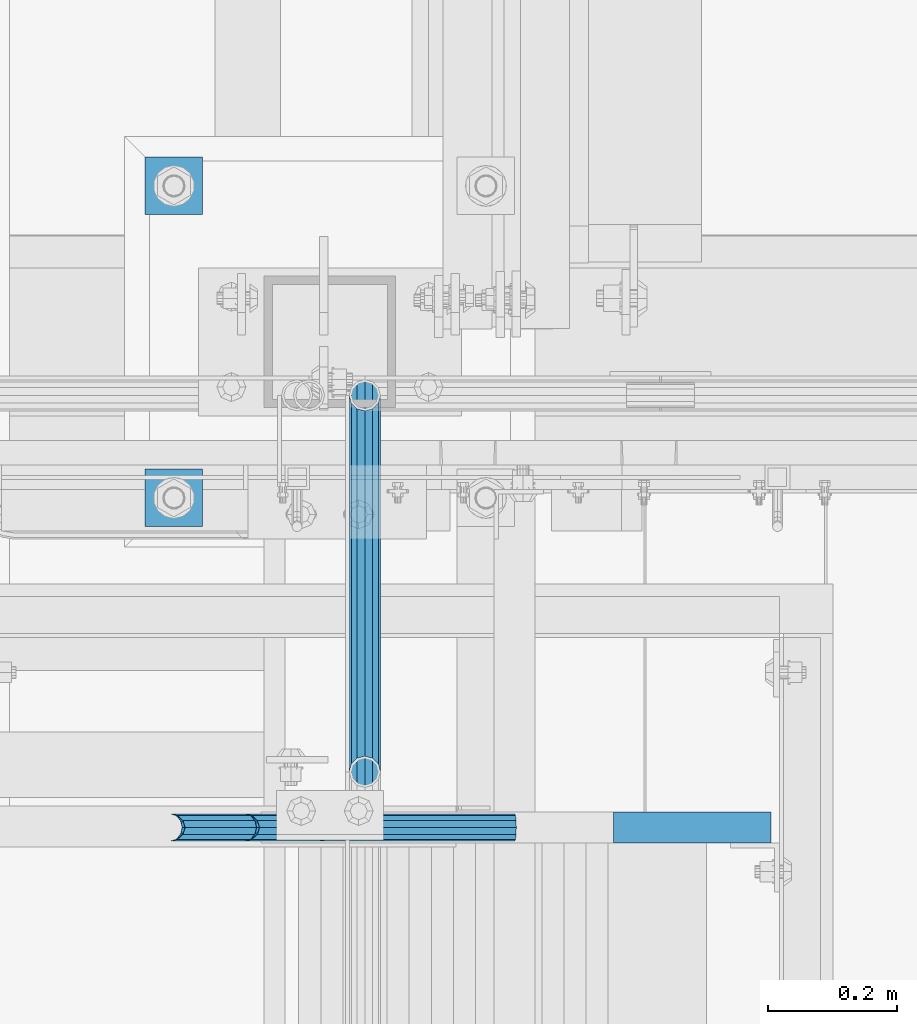
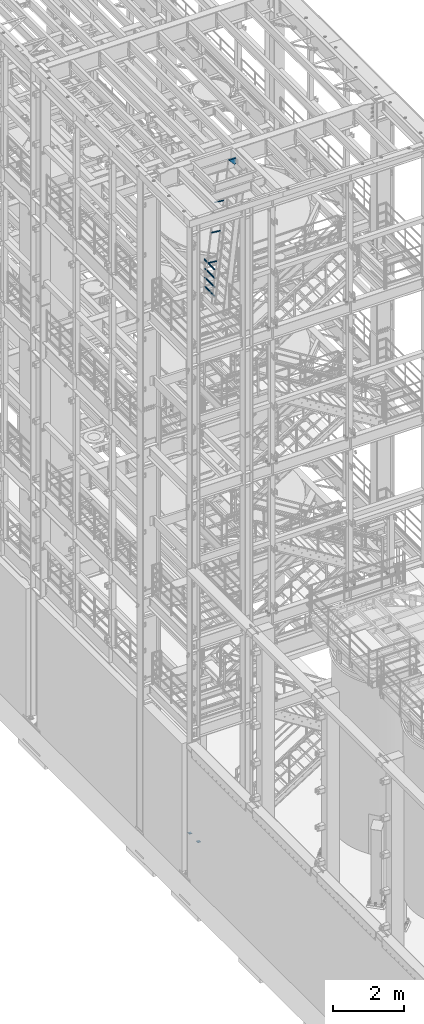
# One storey, part 1165 of 1876: 10 beams, 3 elements without a shape of their own.
"""IFC2X3 building model written with IfcOpenShell, lengths in millimetres."""

from ifc_helpers import new_model, si_unit, frame, origin_with_axes, place, context, subcontext, project, spatial, faceted_brep, material, type_object, element, aggregate, save


model = new_model("IFC2X3")

# Units and contexts
model_context = context("Model", 3, precision=1e-05, world=origin_with_axes())
body_context = subcontext(model_context, "Body", "Model", "MODEL_VIEW")
ifc_project = project(units=[si_unit("LENGTHUNIT", "METRE", prefix="MILLI"), si_unit("AREAUNIT", "SQUARE_METRE"), si_unit("VOLUMEUNIT", "CUBIC_METRE"), si_unit("MASSUNIT", "GRAM", prefix="KILO"), si_unit("TIMEUNIT", "SECOND"), si_unit("PLANEANGLEUNIT", "RADIAN"), si_unit("SOLIDANGLEUNIT", "STERADIAN"), si_unit("THERMODYNAMICTEMPERATUREUNIT", "DEGREE_CELSIUS"), si_unit("LUMINOUSINTENSITYUNIT", "LUMEN")], contexts=[model_context])

# Site, building, storey
site_placement = place(None, origin_with_axes())
site = spatial("IfcSite", under=ifc_project, at=site_placement, CompositionType="ELEMENT")
building_placement = place(site_placement, origin_with_axes())
building = spatial("IfcBuilding", under=site, at=building_placement, Name="Undefined", CompositionType="ELEMENT")
storey_placement = place(building_placement, origin_with_axes())
storey = spatial("IfcBuildingStorey", under=building, at=storey_placement, Name="Undefined", CompositionType="ELEMENT", Elevation=0.0)

# Assembly, beams
assembly_1_placement = place(storey_placement, origin_with_axes())
assembly_1 = element("IfcElementAssembly", 1, at=assembly_1_placement, inside=storey, Name="RAIL", AssemblyPlace="NOTDEFINED", PredefinedType="RIGID_FRAME")
ifc_material_1 = material()
beam_type_1 = type_object("IfcBeamType", Name="PIPE1-1/2SCH40", PredefinedType="NOTDEFINED")
beam_1_placement = place(assembly_1_placement, frame((1781.175, -4654.55000114554, 18145.125), z_axis=(0.0, 0.0, 1.0), x_axis=(0.0, -1.0, 0.0)))
beam_1 = element("IfcBeam", 2, at=beam_1_placement, type_object=beam_type_1, material=ifc_material_1, Name="RAIL", ObjectType="PIPE1-1/2SCH40", context=body_context, shape_type="Brep", body=[
    faceted_brep([(561.397805861145, -12.0650000000001, 20.8971929933177), (561.397805861145, -12.0649999999987, 15.8661214311833), (560.904377423283, -10.2235000000001, 17.7076214311819), (558.164998854463, 0.0, 20.4470000000001), (558.164998854463, 0.0, 24.130000000001), (560.904377423282, 10.2235000000001, 17.7076214311819), (561.397805861145, 12.0650000000014, 15.8661214311796), (561.397805861145, 12.0650000000001, 20.8971929933177), (582.294998854463, 24.1300000000001, 0.0), (570.229998854463, 20.8971929933184, 12.0649999999987), (570.229998854463, 20.8971929933184, -12.0649999999987), (567.040427292323, 17.7076214311803, 10.2235000000001), (569.779805861143, 20.4469999999999, 0.0), (567.040427292323, 17.7076214311803, -10.2235000000001), (561.397805861145, 12.0650000000014, -15.8661214311796), (561.397805861145, 12.0650000000001, -20.8971929933177), (560.904377423282, 10.2235000000001, -17.7076214311819), (558.164998854463, 0.0, -20.4470000000001), (558.164998854463, 0.0, -24.130000000001), (561.397805861145, -12.0649999999987, -15.8661214311833), (561.397805861145, -12.0650000000001, -20.8971929933177), (560.904377423283, -10.2235000000001, -17.7076214311819), (582.294998854463, -24.1299999999987, 0.0), (570.229998854464, -20.8971929933184, -12.0649999999987), (570.229998854464, -20.8971929933184, 12.0649999999987), (567.040427292327, -17.7076214311803, -10.2235000000001), (569.779805861146, -20.4469999999999, 0.0), (567.040427292327, -17.7076214311803, 10.2235000000001), (12.0650000000064, -20.8971929933177, -12.0649999999987), (20.8971929933249, -12.0650000000005, -20.8971929933177), (0.0, 24.1299999999992, 0.0), (12.0650000000064, 20.8971929933177, -12.0649999999987), (12.0650000000064, 20.8971929933177, 12.0649999999987), (20.8971929933249, 12.0650000000005, 20.8971929933177), (24.1300000000064, 0.0, 24.130000000001), (20.8971929933249, 12.0650000000005, -20.8971929933177), (24.1300000000063, 0.0, -24.130000000001), (24.1300000000063, 0.0, -20.4470000000001), (20.8971929933249, -12.0650000000005, -15.8661214311796), (21.3906214311868, -10.2235000000001, -17.7076214311819), (21.3906214311868, 10.2235000000001, -17.7076214311819), (20.8971929933249, 12.0650000000005, -15.8661214311796), (15.2545715621445, 17.7076214311801, -10.2235000000001), (12.5151929933249, 20.4470000000001, 0.0), (15.2545715621445, 17.7076214311801, 10.2235000000001), (20.8971929933249, 12.0650000000005, 15.8661214311796), (21.3906214311868, 10.2235000000001, 17.7076214311819), (24.1300000000064, 0.0, 20.4470000000001), (21.3906214311868, -10.2235000000001, 17.7076214311819), (20.8971929933249, -12.0650000000005, 15.8661214311796), (20.8971929933249, -12.0650000000005, 20.8971929933177), (12.0650000000064, -20.8971929933177, 12.0649999999987), (0.0, -24.1299999999992, 0.0), (15.2545715621445, -17.7076214311801, 10.2235000000001), (12.5151929933249, -20.4470000000001, 0.0), (15.2545715621445, -17.7076214311801, -10.2235000000001)], [[[0, 1, 2, 3, 4]], [[4, 3, 5, 6, 7]], [[8, 9, 10]], [[7, 6, 11, 12, 13, 14, 15, 10, 9]], [[16, 17, 18, 15, 14]], [[19, 20, 18, 17, 21]], [[22, 23, 24]], [[24, 23, 20, 19, 25, 26, 27, 1, 0]], [[28, 29, 20, 23]], [[30, 31, 32]], [[33, 34, 4, 7]], [[32, 33, 7, 9]], [[30, 32, 9, 8]], [[31, 30, 8, 10]], [[35, 31, 10, 15]], [[36, 35, 15, 18]], [[29, 36, 18, 20]], [[37, 36, 29, 38, 39]], [[40, 41, 35, 36, 37]], [[32, 31, 35, 41, 42, 43, 44, 45, 33]], [[33, 45, 46, 47, 34]], [[34, 47, 48, 49, 50]], [[34, 50, 0, 4]], [[50, 51, 24, 0]], [[51, 52, 22, 24]], [[52, 28, 23, 22]], [[51, 28, 52]], [[50, 49, 53, 54, 55, 38, 29, 28, 51]], [[55, 54, 26, 25]], [[21, 39, 38, 55, 25, 19]], [[37, 39, 21, 17]], [[40, 37, 17, 16]], [[42, 41, 40, 16, 14, 13]], [[43, 42, 13, 12]], [[44, 43, 12, 11]], [[5, 46, 45, 44, 11, 6]], [[47, 46, 5, 3]], [[48, 47, 3, 2]], [[53, 49, 48, 2, 1, 27]], [[54, 53, 27, 26]]]),
])
beam_2_placement = place(assembly_1_placement, frame((1781.175, -5236.845, 18449.925), z_axis=(0.0, 0.0, -1.0), x_axis=(0.0, 1.0, 0.0)))
beam_2 = element("IfcBeam", 3, at=beam_2_placement, type_object=beam_type_1, material=ifc_material_1, Name="RAIL", ObjectType="PIPE1-1/2SCH40", context=body_context, shape_type="Brep", body=[
    faceted_brep([(0.0, 24.1299999999992, 0.0), (12.0650000000064, 20.8971929933177, -12.0649999999987), (12.0650000000064, 20.8971929933177, 12.0649999999987), (12.0650000000064, -20.8971929933177, 12.0649999999987), (12.0650000000064, -20.8971929933177, -12.0649999999987), (0.0, -24.1299999999992, 0.0), (20.8971929933249, -12.0650000000005, 20.8971929933177), (20.8971929933249, -12.0650000000005, 15.8661214311796), (15.2545715621445, -17.7076214311801, 10.2235000000001), (12.5151929933249, -20.4470000000001, 0.0), (15.2545715621445, -17.7076214311801, -10.2235000000001), (20.8971929933249, -12.0650000000005, -15.8661214311796), (20.8971929933249, -12.0650000000005, -20.8971929933177), (24.1300000000063, 0.0, -20.4470000000001), (24.1300000000063, 0.0, -24.130000000001), (21.3906214311868, -10.2235000000001, -17.7076214311819), (21.3906214311868, 10.2235000000001, -17.7076214311819), (20.8971929933249, 12.0650000000005, -15.8661214311796), (20.8971929933249, 12.0650000000005, -20.8971929933177), (15.2545715621445, 17.7076214311801, -10.2235000000001), (12.5151929933249, 20.4470000000001, 0.0), (15.2545715621445, 17.7076214311801, 10.2235000000001), (20.8971929933249, 12.0650000000005, 15.8661214311796), (20.8971929933249, 12.0650000000005, 20.8971929933177), (21.3906214311868, 10.2235000000001, 17.7076214311819), (24.1300000000064, 0.0, 20.4470000000001), (24.1300000000064, 0.0, 24.130000000001), (21.3906214311868, -10.2235000000001, 17.7076214311819), (582.294998854463, 24.1300000000001, 0.0), (570.229998854463, 20.8971929933184, -12.0649999999987), (561.397805861145, 12.0650000000001, -20.8971929933177), (582.294998854463, -24.1299999999987, 0.0), (570.229998854464, -20.8971929933184, -12.0649999999987), (570.229998854464, -20.8971929933184, 12.0649999999987), (561.397805861145, -12.0650000000001, 20.8971929933177), (561.397805861145, -12.0650000000001, -20.8971929933177), (558.164998854463, 0.0, -24.130000000001), (560.904377423282, 10.2235000000001, -17.7076214311819), (558.164998854463, 0.0, -20.4470000000001), (561.397805861145, 12.0650000000014, -15.8661214311796), (561.397805861145, -12.0649999999987, -15.8661214311833), (560.904377423283, -10.2235000000001, -17.7076214311819), (567.040427292327, -17.7076214311803, -10.2235000000001), (569.779805861146, -20.4469999999999, 0.0), (567.040427292327, -17.7076214311803, 10.2235000000001), (561.397805861145, -12.0649999999987, 15.8661214311833), (560.904377423283, -10.2235000000001, 17.7076214311819), (558.164998854463, 0.0, 20.4470000000001), (558.164998854463, 0.0, 24.130000000001), (561.397805861145, 12.0650000000001, 20.8971929933177), (570.229998854463, 20.8971929933184, 12.0649999999987), (561.397805861145, 12.0650000000014, 15.8661214311796), (567.040427292323, 17.7076214311803, 10.2235000000001), (569.779805861143, 20.4469999999999, 0.0), (567.040427292323, 17.7076214311803, -10.2235000000001), (560.904377423282, 10.2235000000001, 17.7076214311819)], [[[0, 1, 2]], [[3, 4, 5]], [[6, 7, 8, 9, 10, 11, 12, 4, 3]], [[13, 14, 12, 11, 15]], [[16, 17, 18, 14, 13]], [[2, 1, 18, 17, 19, 20, 21, 22, 23]], [[23, 22, 24, 25, 26]], [[26, 25, 27, 7, 6]], [[1, 0, 28, 29]], [[18, 1, 29, 30]], [[31, 32, 33]], [[6, 3, 33, 34]], [[3, 5, 31, 33]], [[5, 4, 32, 31]], [[4, 12, 35, 32]], [[12, 14, 36, 35]], [[14, 18, 30, 36]], [[37, 38, 36, 30, 39]], [[40, 35, 36, 38, 41]], [[33, 32, 35, 40, 42, 43, 44, 45, 34]], [[34, 45, 46, 47, 48]], [[26, 6, 34, 48]], [[2, 23, 49, 50]], [[23, 26, 48, 49]], [[0, 2, 50, 28]], [[28, 50, 29]], [[49, 51, 52, 53, 54, 39, 30, 29, 50]], [[48, 47, 55, 51, 49]], [[25, 24, 55, 47]], [[55, 24, 22, 21, 52, 51]], [[21, 20, 53, 52]], [[20, 19, 54, 53]], [[19, 17, 16, 37, 39, 54]], [[16, 13, 38, 37]], [[13, 15, 41, 38]], [[41, 15, 11, 10, 42, 40]], [[10, 9, 43, 42]], [[9, 8, 44, 43]], [[8, 7, 27, 46, 45, 44]], [[27, 25, 47, 46]]]),
])
beam_3_placement = place(assembly_1_placement, frame((1781.175, -5236.845, 18754.725), z_axis=(0.0, 0.0, -1.0), x_axis=(0.0, 1.0, 0.0)))
beam_3 = element("IfcBeam", 4, at=beam_3_placement, type_object=beam_type_1, material=ifc_material_1, Name="RAIL", ObjectType="PIPE1-1/2SCH40", context=body_context, shape_type="Brep", body=[
    faceted_brep([(0.0, 24.1299999999992, 0.0), (12.0650000000064, 20.8971929933177, -12.0649999999987), (12.0650000000064, 20.8971929933177, 12.0649999999987), (12.0650000000064, -20.8971929933177, 12.0649999999987), (12.0650000000064, -20.8971929933177, -12.0649999999987), (0.0, -24.1299999999992, 0.0), (20.8971929933249, -12.0650000000005, 20.8971929933177), (20.8971929933249, -12.0650000000005, 15.8661214311796), (15.2545715621445, -17.7076214311801, 10.2235000000001), (12.5151929933249, -20.4470000000001, 0.0), (15.2545715621445, -17.7076214311801, -10.2235000000001), (20.8971929933249, -12.0650000000005, -15.8661214311796), (20.8971929933249, -12.0650000000005, -20.8971929933177), (24.1300000000063, 0.0, -20.4470000000001), (24.1300000000063, 0.0, -24.130000000001), (21.3906214311868, -10.2235000000001, -17.7076214311819), (21.3906214311868, 10.2235000000001, -17.7076214311819), (20.8971929933249, 12.0650000000005, -15.8661214311796), (20.8971929933249, 12.0650000000005, -20.8971929933177), (15.2545715621445, 17.7076214311801, -10.2235000000001), (12.5151929933249, 20.4470000000001, 0.0), (15.2545715621445, 17.7076214311801, 10.2235000000001), (20.8971929933249, 12.0650000000005, 15.8661214311796), (20.8971929933249, 12.0650000000005, 20.8971929933177), (21.3906214311868, 10.2235000000001, 17.7076214311819), (24.1300000000064, 0.0, 20.4470000000001), (24.1300000000064, 0.0, 24.130000000001), (21.3906214311868, -10.2235000000001, 17.7076214311819), (582.294998854463, 24.1300000000001, 0.0), (570.229998854463, 20.8971929933184, -12.0649999999987), (561.397805861145, 12.0650000000001, -20.8971929933177), (582.294998854463, -24.1299999999987, 0.0), (570.229998854464, -20.8971929933184, -12.0649999999987), (570.229998854464, -20.8971929933184, 12.0649999999987), (561.397805861145, -12.0650000000001, 20.8971929933177), (561.397805861145, -12.0650000000001, -20.8971929933177), (558.164998854463, 0.0, -24.130000000001), (560.904377423282, 10.2235000000001, -17.7076214311819), (558.164998854463, 0.0, -20.4470000000001), (561.397805861145, 12.0650000000014, -15.8661214311796), (561.397805861145, -12.0649999999987, -15.8661214311833), (560.904377423283, -10.2235000000001, -17.7076214311819), (567.040427292327, -17.7076214311803, -10.2235000000001), (569.779805861146, -20.4469999999999, 0.0), (567.040427292327, -17.7076214311803, 10.2235000000001), (561.397805861145, -12.0649999999987, 15.8661214311833), (560.904377423283, -10.2235000000001, 17.7076214311819), (558.164998854463, 0.0, 20.4470000000001), (558.164998854463, 0.0, 24.130000000001), (561.397805861145, 12.0650000000001, 20.8971929933177), (570.229998854463, 20.8971929933184, 12.0649999999987), (561.397805861145, 12.0650000000014, 15.8661214311796), (567.040427292323, 17.7076214311803, 10.2235000000001), (569.779805861143, 20.4469999999999, 0.0), (567.040427292323, 17.7076214311803, -10.2235000000001), (560.904377423282, 10.2235000000001, 17.7076214311819)], [[[0, 1, 2]], [[3, 4, 5]], [[6, 7, 8, 9, 10, 11, 12, 4, 3]], [[13, 14, 12, 11, 15]], [[16, 17, 18, 14, 13]], [[2, 1, 18, 17, 19, 20, 21, 22, 23]], [[23, 22, 24, 25, 26]], [[26, 25, 27, 7, 6]], [[1, 0, 28, 29]], [[18, 1, 29, 30]], [[31, 32, 33]], [[6, 3, 33, 34]], [[3, 5, 31, 33]], [[5, 4, 32, 31]], [[4, 12, 35, 32]], [[12, 14, 36, 35]], [[14, 18, 30, 36]], [[37, 38, 36, 30, 39]], [[40, 35, 36, 38, 41]], [[33, 32, 35, 40, 42, 43, 44, 45, 34]], [[34, 45, 46, 47, 48]], [[26, 6, 34, 48]], [[2, 23, 49, 50]], [[23, 26, 48, 49]], [[0, 2, 50, 28]], [[28, 50, 29]], [[49, 51, 52, 53, 54, 39, 30, 29, 50]], [[48, 47, 55, 51, 49]], [[25, 24, 55, 47]], [[55, 24, 22, 21, 52, 51]], [[21, 20, 53, 52]], [[20, 19, 54, 53]], [[19, 17, 16, 37, 39, 54]], [[16, 13, 38, 37]], [[13, 15, 41, 38]], [[41, 15, 11, 10, 42, 40]], [[10, 9, 43, 42]], [[9, 8, 44, 43]], [[8, 7, 27, 46, 45, 44]], [[27, 25, 47, 46]]]),
])
beam_4_placement = place(assembly_1_placement, frame((1781.175, -5260.975, 19059.525), z_axis=(0.0, 0.0, -1.0), x_axis=(0.0, 1.0, 0.0)))
beam_4 = element("IfcBeam", 5, at=beam_4_placement, type_object=beam_type_1, material=ifc_material_1, Name="RAIL", ObjectType="PIPE1-1/2SCH40", context=body_context, shape_type="Brep", body=[
    faceted_brep([(24.1300000000001, -20.4469999999999, 0.0), (34.3535000000002, -17.7076214311803, 10.2235000000001), (596.201498854463, -17.7076214311803, 10.2235000000001), (606.424998854463, -20.4469999999999, 0.0), (41.8376214311802, -10.2235000000001, 17.7076214311819), (588.717377423283, -10.2235000000001, 17.7076214311819), (44.5770000000002, 0.0, 20.4470000000001), (585.977998854463, 0.0, 20.4470000000001), (41.8376214311802, 10.2235000000001, 17.7076214311819), (588.717377423283, 10.2235000000001, 17.7076214311819), (34.3535000000002, 17.7076214311803, 10.2235000000001), (596.201498854463, 17.7076214311803, 10.2235000000001), (24.1300000000001, 20.4469999999999, 0.0), (606.424998854463, 20.4469999999999, 0.0), (13.9065000000001, 17.7076214311803, -10.2235000000001), (616.648498854463, 17.7076214311803, -10.2235000000001), (6.42237856882002, 10.2235000000001, -17.7076214311819), (624.132620285643, 10.2235000000001, -17.7076214311819), (3.68299999999999, 0.0, -20.4470000000001), (626.871998854464, 0.0, -20.4470000000001), (6.42237856882002, -10.2235000000001, -17.7076214311819), (624.132620285643, -10.2235000000001, -17.7076214311819), (13.9065000000001, -17.7076214311803, -10.2235000000001), (616.648498854463, -17.7076214311803, -10.2235000000001), (24.1299999999854, -24.1299999999992, 0.0), (12.0650000000064, -20.8971929933177, -12.0649999999987), (618.489998854463, -20.8971929933184, -12.0649999999987), (606.424998854463, -24.1300000000001, 0.0), (3.23280700668147, -12.0650000000001, -20.8971929933177), (627.322191847782, -12.0650000000001, -20.8971929933177), (-1.45519152283669e-11, 0.0, -24.130000000001), (630.554998854464, 0.0, -24.130000000001), (3.23280700668147, 12.0650000000001, -20.8971929933177), (627.322191847782, 12.0650000000001, -20.8971929933177), (12.0650000000064, 20.8971929933177, -12.0649999999987), (618.489998854463, 20.8971929933184, -12.0649999999987), (24.1300000000047, 24.1299999999992, 0.0), (606.424998854463, 24.1300000000001, 0.0), (36.1949999999997, 20.8971929933184, 12.0649999999987), (594.359998854464, 20.8971929933184, 12.0649999999987), (45.0271929933187, 12.0650000000001, 20.8971929933177), (585.527805861145, 12.0650000000001, 20.8971929933177), (48.2600000000002, 0.0, 24.130000000001), (582.294998854463, 0.0, 24.130000000001), (45.0271929933187, -12.0650000000001, 20.8971929933177), (585.527805861145, -12.0650000000001, 20.8971929933177), (36.1949999999997, -20.8971929933184, 12.0649999999987), (594.359998854464, -20.8971929933184, 12.0649999999987)], [[[0, 1, 2, 3]], [[1, 4, 5, 2]], [[4, 6, 7, 5]], [[6, 8, 9, 7]], [[8, 10, 11, 9]], [[10, 12, 13, 11]], [[12, 14, 15, 13]], [[14, 16, 17, 15]], [[16, 18, 19, 17]], [[18, 20, 21, 19]], [[20, 22, 23, 21]], [[22, 0, 3, 23]], [[24, 25, 26, 27]], [[25, 28, 29, 26]], [[28, 30, 31, 29]], [[30, 32, 33, 31]], [[32, 34, 35, 33]], [[34, 36, 37, 35]], [[36, 38, 39, 37]], [[38, 40, 41, 39]], [[40, 42, 43, 41]], [[42, 44, 45, 43]], [[44, 46, 47, 45]], [[46, 24, 27, 47]], [[29, 31, 33, 35, 37, 39, 41, 43, 45, 47, 27, 26], [5, 7, 9, 11, 13, 15, 17, 19, 21, 23, 3, 2]], [[46, 44, 42, 40, 38, 36, 34, 32, 30, 28, 25, 24], [22, 20, 18, 16, 14, 12, 10, 8, 6, 4, 1, 0]]]),
])
aggregate(assembly_1, [beam_1, beam_2, beam_3, beam_4])

assembly_2_placement = place(storey_placement, origin_with_axes())
assembly_2 = element("IfcElementAssembly", 6, at=assembly_2_placement, inside=storey, Name="RIGHT STRINGER", AssemblyPlace="NOTDEFINED", PredefinedType="RIGID_FRAME")
beam_type_2 = type_object("IfcBeamType", Name="PIPE1-1/4SCH40", PredefinedType="NOTDEFINED")
beam_5_placement = place(assembly_2_placement, frame((1710.20842451598, -5322.8875, 21456.6097432816), z_axis=(0.0, -1.0, 0.0), x_axis=(0.993502247476981, 0.0, -0.113812496054638)))
beam_5 = element("IfcBeam", 7, at=beam_5_placement, type_object=beam_type_2, material=ifc_material_1, Name="POST", ObjectType="PIPE1-1/4SCH40", context=body_context, shape_type="Brep", body=[
    faceted_brep([(0.0, 0.0, 21.0820000000003), (10.5410047402225, 10.5410000000047, 18.2575475625836), (10.5410000000002, -10.5410000000002, 18.2575475625836), (10.5410000000002, -10.5410000000002, -18.2575475625836), (10.5410047402225, 10.5410000000047, -18.2575475625836), (-4.28826751885936e-09, 0.0, -21.0820000000003), (18.2575475625836, -18.2575475625836, -10.5409999999993), (18.2575523716411, -13.3999612267653, -10.5410000000002), (13.6205911385651, -8.76300000002811, -15.1779612267264), (11.2725523401174, -1.09139364212751e-11, -17.5259999999998), (13.6205910882173, 8.76299999999537, -15.1779612267264), (18.2575522945893, 13.3999612267216, -10.5410000000002), (18.2575522806238, 18.2575475625817, -10.5410000000002), (21.0819999957121, 17.5259999907203, 0.0), (21.081999995713, 21.0819999907208, 0.0), (18.7339659606611, 15.1779612267237, -8.76299999999992), (18.7339659606627, 15.1779612267237, 8.76299999999992), (18.2575522945893, 13.3999612267216, 10.5410000000002), (18.2575522806238, 18.2575475625817, 10.5410000000002), (13.6205910882217, 8.76299999999537, 15.1779612267264), (11.2725523401217, -1.09139364212751e-11, 17.5259999999998), (13.6205911385692, -8.76300000002811, 15.1779612267264), (18.2575523716411, -13.3999612267653, 10.5410000000002), (18.2575475625836, -18.2575475625836, 10.5409999999993), (18.7339660478675, -15.177961226771, 8.76299999999992), (21.0819999957121, -17.5260000092794, 0.0), (21.0819999957121, -21.0820000092799, 0.0), (18.7339660478659, -15.177961226771, -8.76299999999992), (304.800009609033, -10.5410000004813, -18.2575475625836), (304.800009609034, -18.2575475630765, -10.5410000000002), (304.800009609031, -4.69299266114831e-10, -21.0820000000003), (304.800009609029, 10.5409999995427, -18.2575475625836), (304.800009609028, 18.2575475621416, -10.5410000000002), (304.800009609028, 21.0819999995583, 0.0), (304.800009609028, 18.2575475621416, 10.5410000000002), (304.800009609029, 10.5409999995427, 18.2575475625836), (304.800009609031, -4.69299266114831e-10, 21.0820000000003), (304.800009609033, -10.5410000004813, 18.2575475625836), (304.800009609034, -18.2575475630765, 10.5410000000002), (304.800009609035, -21.0820000004969, 0.0), (304.800009609033, -8.76300000047922, 15.1779612267264), (304.800009609031, -4.69299266114831e-10, 17.5259999999998), (304.800009609029, 8.76299999954426, 15.1779612267264), (304.800009609029, 15.1779612262762, 8.76299999999992), (304.800009609028, 17.5259999995542, 0.0), (304.800009609029, 15.1779612262762, -8.76299999999992), (304.800009609029, 8.76299999954426, -15.1779612267264), (304.800009609031, -4.69299266114831e-10, -17.5259999999998), (304.800009609033, -8.76300000047922, -15.1779612267264), (304.800009609034, -15.1779612272148, -8.76299999999992), (304.800009609034, -17.5260000004928, 0.0), (304.800009609034, -15.1779612272148, 8.76299999999992)], [[[0, 1, 2]], [[3, 4, 5]], [[6, 7, 8, 9, 10, 11, 12, 4, 3]], [[13, 14, 12, 11, 15]], [[16, 17, 18, 14, 13]], [[2, 1, 18, 17, 19, 20, 21, 22, 23]], [[23, 22, 24, 25, 26]], [[26, 25, 27, 7, 6]], [[28, 29, 6, 3]], [[30, 28, 3, 5]], [[31, 30, 5, 4]], [[32, 31, 4, 12]], [[33, 32, 12, 14]], [[34, 33, 14, 18]], [[35, 34, 18, 1]], [[36, 35, 1, 0]], [[37, 36, 0, 2]], [[38, 37, 2, 23]], [[39, 38, 23, 26]], [[29, 39, 26, 6]], [[28, 30, 31, 32, 33, 34, 35, 36, 37, 38, 39, 29], [40, 41, 42, 43, 44, 45, 46, 47, 48, 49, 50, 51]], [[51, 50, 25, 24]], [[21, 40, 51, 24, 22]], [[41, 40, 21, 20]], [[42, 41, 20, 19]], [[43, 42, 19, 17, 16]], [[44, 43, 16, 13]], [[45, 44, 13, 15]], [[10, 46, 45, 15, 11]], [[47, 46, 10, 9]], [[48, 47, 9, 8]], [[49, 48, 8, 7, 27]], [[50, 49, 27, 25]]]),
])
beam_6_placement = place(assembly_2_placement, frame((1595.07831468453, -5322.8875, 20451.6057135354), z_axis=(0.0, -1.0, 0.0), x_axis=(0.993502247476981, 0.0, -0.113812496054638)))
beam_6 = element("IfcBeam", 8, at=beam_6_placement, type_object=beam_type_2, material=ifc_material_1, Name="POST", ObjectType="PIPE1-1/4SCH40", context=body_context, shape_type="Brep", body=[
    faceted_brep([(0.0, 0.0, 21.0820000000003), (10.5410047402225, 10.5410000000047, 18.2575475625836), (10.5410000000002, -10.5410000000002, 18.2575475625836), (10.5410000000002, -10.5410000000002, -18.2575475625836), (10.5410047402225, 10.5410000000047, -18.2575475625836), (-4.28826751885936e-09, 0.0, -21.0820000000003), (18.2575475625836, -18.2575475625836, -10.5409999999993), (18.2575523716411, -13.3999612267653, -10.5410000000002), (13.6205911385651, -8.76300000002811, -15.1779612267264), (11.2725523401174, -1.09139364212751e-11, -17.5259999999998), (13.6205910882173, 8.76299999999537, -15.1779612267264), (18.2575522945893, 13.3999612267216, -10.5410000000002), (18.2575522806238, 18.2575475625817, -10.5410000000002), (21.0819999957121, 17.5259999907203, 0.0), (21.081999995713, 21.0819999907208, 0.0), (18.7339659606611, 15.1779612267237, -8.76299999999992), (18.7339659606627, 15.1779612267237, 8.76299999999992), (18.2575522945893, 13.3999612267216, 10.5410000000002), (18.2575522806238, 18.2575475625817, 10.5410000000002), (13.6205910882217, 8.76299999999537, 15.1779612267264), (11.2725523401217, -1.09139364212751e-11, 17.5259999999998), (13.6205911385692, -8.76300000002811, 15.1779612267264), (18.2575523716411, -13.3999612267653, 10.5410000000002), (18.2575475625836, -18.2575475625836, 10.5409999999993), (18.7339660478675, -15.177961226771, 8.76299999999992), (21.0819999957121, -17.5260000092794, 0.0), (21.0819999957121, -21.0820000092799, 0.0), (18.7339660478659, -15.177961226771, -8.76299999999992), (304.800009609033, -10.5410000004813, -18.2575475625836), (304.800009609034, -18.2575475630765, -10.5410000000002), (304.800009609031, -4.69299266114831e-10, -21.0820000000003), (304.800009609029, 10.5409999995427, -18.2575475625836), (304.800009609028, 18.2575475621416, -10.5410000000002), (304.800009609028, 21.0819999995583, 0.0), (304.800009609028, 18.2575475621416, 10.5410000000002), (304.800009609029, 10.5409999995427, 18.2575475625836), (304.800009609031, -4.69299266114831e-10, 21.0820000000003), (304.800009609033, -10.5410000004813, 18.2575475625836), (304.800009609034, -18.2575475630765, 10.5410000000002), (304.800009609035, -21.0820000004969, 0.0), (304.800009609033, -8.76300000047922, 15.1779612267264), (304.800009609031, -4.69299266114831e-10, 17.5259999999998), (304.800009609029, 8.76299999954426, 15.1779612267264), (304.800009609029, 15.1779612262762, 8.76299999999992), (304.800009609028, 17.5259999995542, 0.0), (304.800009609029, 15.1779612262762, -8.76299999999992), (304.800009609029, 8.76299999954426, -15.1779612267264), (304.800009609031, -4.69299266114831e-10, -17.5259999999998), (304.800009609033, -8.76300000047922, -15.1779612267264), (304.800009609034, -15.1779612272148, -8.76299999999992), (304.800009609034, -17.5260000004928, 0.0), (304.800009609034, -15.1779612272148, 8.76299999999992)], [[[0, 1, 2]], [[3, 4, 5]], [[6, 7, 8, 9, 10, 11, 12, 4, 3]], [[13, 14, 12, 11, 15]], [[16, 17, 18, 14, 13]], [[2, 1, 18, 17, 19, 20, 21, 22, 23]], [[23, 22, 24, 25, 26]], [[26, 25, 27, 7, 6]], [[28, 29, 6, 3]], [[30, 28, 3, 5]], [[31, 30, 5, 4]], [[32, 31, 4, 12]], [[33, 32, 12, 14]], [[34, 33, 14, 18]], [[35, 34, 18, 1]], [[36, 35, 1, 0]], [[37, 36, 0, 2]], [[38, 37, 2, 23]], [[39, 38, 23, 26]], [[29, 39, 26, 6]], [[28, 30, 31, 32, 33, 34, 35, 36, 37, 38, 39, 29], [40, 41, 42, 43, 44, 45, 46, 47, 48, 49, 50, 51]], [[51, 50, 25, 24]], [[21, 40, 51, 24, 22]], [[41, 40, 21, 20]], [[42, 41, 20, 19]], [[43, 42, 19, 17, 16]], [[44, 43, 16, 13]], [[45, 44, 13, 15]], [[10, 46, 45, 15, 11]], [[47, 46, 10, 9]], [[48, 47, 9, 8]], [[49, 48, 8, 7, 27]], [[50, 49, 27, 25]]]),
])
beam_7_placement = place(assembly_2_placement, frame((1479.94820485307, -5322.8875, 19446.6016837892), z_axis=(0.0, -1.0, 0.0), x_axis=(0.993502247476981, 0.0, -0.113812496054638)))
beam_7 = element("IfcBeam", 9, at=beam_7_placement, type_object=beam_type_2, material=ifc_material_1, Name="POST", ObjectType="PIPE1-1/4SCH40", context=body_context, shape_type="Brep", body=[
    faceted_brep([(0.0, 0.0, 21.0820000000003), (10.5410047402225, 10.5410000000047, 18.2575475625836), (10.5410000000002, -10.5410000000002, 18.2575475625836), (10.5410000000002, -10.5410000000002, -18.2575475625836), (10.5410047402225, 10.5410000000047, -18.2575475625836), (-4.28826751885936e-09, 0.0, -21.0820000000003), (18.2575475625836, -18.2575475625836, -10.5409999999993), (18.2575523716411, -13.3999612267653, -10.5410000000002), (13.6205911385651, -8.76300000002811, -15.1779612267264), (11.2725523401174, -1.09139364212751e-11, -17.5259999999998), (13.6205910882173, 8.76299999999537, -15.1779612267264), (18.2575522945893, 13.3999612267216, -10.5410000000002), (18.2575522806238, 18.2575475625817, -10.5410000000002), (21.0819999957121, 17.5259999907203, 0.0), (21.081999995713, 21.0819999907208, 0.0), (18.7339659606611, 15.1779612267237, -8.76299999999992), (18.7339659606627, 15.1779612267237, 8.76299999999992), (18.2575522945893, 13.3999612267216, 10.5410000000002), (18.2575522806238, 18.2575475625817, 10.5410000000002), (13.6205910882217, 8.76299999999537, 15.1779612267264), (11.2725523401217, -1.09139364212751e-11, 17.5259999999998), (13.6205911385692, -8.76300000002811, 15.1779612267264), (18.2575523716411, -13.3999612267653, 10.5410000000002), (18.2575475625836, -18.2575475625836, 10.5409999999993), (18.7339660478675, -15.177961226771, 8.76299999999992), (21.0819999957121, -17.5260000092794, 0.0), (21.0819999957121, -21.0820000092799, 0.0), (18.7339660478659, -15.177961226771, -8.76299999999992), (304.800009609033, -10.5410000004813, -18.2575475625836), (304.800009609034, -18.2575475630765, -10.5410000000002), (304.800009609031, -4.69299266114831e-10, -21.0820000000003), (304.800009609029, 10.5409999995427, -18.2575475625836), (304.800009609028, 18.2575475621416, -10.5410000000002), (304.800009609028, 21.0819999995583, 0.0), (304.800009609028, 18.2575475621416, 10.5410000000002), (304.800009609029, 10.5409999995427, 18.2575475625836), (304.800009609031, -4.69299266114831e-10, 21.0820000000003), (304.800009609033, -10.5410000004813, 18.2575475625836), (304.800009609034, -18.2575475630765, 10.5410000000002), (304.800009609035, -21.0820000004969, 0.0), (304.800009609033, -8.76300000047922, 15.1779612267264), (304.800009609031, -4.69299266114831e-10, 17.5259999999998), (304.800009609029, 8.76299999954426, 15.1779612267264), (304.800009609029, 15.1779612262762, 8.76299999999992), (304.800009609028, 17.5259999995542, 0.0), (304.800009609029, 15.1779612262762, -8.76299999999992), (304.800009609029, 8.76299999954426, -15.1779612267264), (304.800009609031, -4.69299266114831e-10, -17.5259999999998), (304.800009609033, -8.76300000047922, -15.1779612267264), (304.800009609034, -15.1779612272148, -8.76299999999992), (304.800009609034, -17.5260000004928, 0.0), (304.800009609034, -15.1779612272148, 8.76299999999992)], [[[0, 1, 2]], [[3, 4, 5]], [[6, 7, 8, 9, 10, 11, 12, 4, 3]], [[13, 14, 12, 11, 15]], [[16, 17, 18, 14, 13]], [[2, 1, 18, 17, 19, 20, 21, 22, 23]], [[23, 22, 24, 25, 26]], [[26, 25, 27, 7, 6]], [[28, 29, 6, 3]], [[30, 28, 3, 5]], [[31, 30, 5, 4]], [[32, 31, 4, 12]], [[33, 32, 12, 14]], [[34, 33, 14, 18]], [[35, 34, 18, 1]], [[36, 35, 1, 0]], [[37, 36, 0, 2]], [[38, 37, 2, 23]], [[39, 38, 23, 26]], [[29, 39, 26, 6]], [[28, 30, 31, 32, 33, 34, 35, 36, 37, 38, 39, 29], [40, 41, 42, 43, 44, 45, 46, 47, 48, 49, 50, 51]], [[51, 50, 25, 24]], [[21, 40, 51, 24, 22]], [[41, 40, 21, 20]], [[42, 41, 20, 19]], [[43, 42, 19, 17, 16]], [[44, 43, 16, 13]], [[45, 44, 13, 15]], [[10, 46, 45, 15, 11]], [[47, 46, 10, 9]], [[48, 47, 9, 8]], [[49, 48, 8, 7, 27]], [[50, 49, 27, 25]]]),
])
ifc_material_2 = material(Name="STEEL/A36")
beam_type_3 = type_object("IfcBeamType", Name="MC8X8.5", PredefinedType="NOTDEFINED")
beam_8_placement = place(assembly_2_placement, frame((2166.11762806435, -5322.8875, 22656.8), z_axis=(0.0, 0.0, -1.0), x_axis=(1.0, 0.0, 0.0)))
beam_8 = element("IfcBeam", 10, at=beam_8_placement, type_object=beam_type_3, material=ifc_material_2, Name="LADDER", ObjectType="MC8X8.5", context=body_context, shape_type="Brep", body=[
    faceted_brep([(9.9464159575291e-08, 23.8125, -101.599999999999), (181.250957503763, 23.8125, 101.599999999999), (243.053623451269, 23.8125, 101.599999999999), (243.053623451269, 23.8125, -101.599999999999), (181.250957503763, -23.8125, 101.599999999999), (243.053623451269, -23.8125, 101.599999999999), (174.593524876916, -23.8125, 94.1363687500016), (243.053623451269, -23.8125, 94.1363687500016), (173.83269566275, 19.0500000000002, 93.2834049999983), (243.053623451269, 19.0500000000002, 93.2834049999983), (7.4182619404769, 19.0500000000002, -93.2834049999983), (243.053623451269, 19.0500000000002, -93.2834049999983), (6.65743272631016, -23.8125, -94.1363687500016), (243.053623451269, -23.8125, -94.1363687500016), (9.9464159575291e-08, -23.8125, -101.599999999999), (243.053623451269, -23.8125, -101.599999999999)], [[[0, 1, 2, 3]], [[1, 4, 5, 2]], [[4, 6, 7, 5]], [[6, 8, 9, 7]], [[8, 10, 11, 9]], [[10, 12, 13, 11]], [[12, 14, 15, 13]], [[14, 0, 3, 15]], [[5, 7, 9, 11, 13, 15, 3, 2]], [[14, 12, 10, 8, 6, 4, 1, 0]]]),
])
aggregate(assembly_2, [beam_5, beam_6, beam_7, beam_8])

assembly_3_placement = place(storey_placement, origin_with_axes())
assembly_3 = element("IfcElementAssembly", 11, at=assembly_3_placement, inside=storey, Name="TEMPLATE", AssemblyPlace="NOTDEFINED", PredefinedType="RIGID_FRAME")
ifc_material_3 = material(Name="STEEL/A572-GR.50")
beam_type_4 = type_object("IfcBeamType", PredefinedType="NOTDEFINED")
beam_9_placement = place(assembly_3_placement, frame((1530.35, -4813.3, -781.05), z_axis=(0.0, 1.0, 0.0), x_axis=(-1.0, 0.0, 0.0)))
beam_9 = element("IfcBeam", 12, at=beam_9_placement, type_object=beam_type_4, material=ifc_material_3, Name="PLATE", context=body_context, shape_type="Brep", body=[
    faceted_brep([(0.0, 6.35000000000002, -44.4499999999998), (0.0, 6.35000000000002, 44.4499999999998), (88.9000000000001, 6.35000000000002, 44.4499999999998), (88.9000000000001, 6.35000000000002, -44.4499999999998), (0.0, -6.35000000000002, 44.4499999999998), (88.9000000000001, -6.35000000000002, 44.4499999999998), (0.0, -6.35000000000002, -44.4499999999998), (88.9000000000001, -6.35000000000002, -44.4499999999998)], [[[0, 1, 2, 3]], [[1, 4, 5, 2]], [[4, 6, 7, 5]], [[6, 0, 3, 7]], [[5, 7, 3, 2]], [[6, 4, 1, 0]]]),
])
beam_10_placement = place(assembly_3_placement, frame((1530.35, -4330.7, -781.05), z_axis=(0.0, 1.0, 0.0), x_axis=(-1.0, 0.0, 0.0)))
beam_10 = element("IfcBeam", 13, at=beam_10_placement, type_object=beam_type_4, material=ifc_material_3, Name="PLATE", context=body_context, shape_type="Brep", body=[
    faceted_brep([(0.0, 6.35000000000002, -44.4499999999998), (0.0, 6.35000000000002, 44.4499999999998), (88.9000000000001, 6.35000000000002, 44.4499999999998), (88.9000000000001, 6.35000000000002, -44.4499999999998), (0.0, -6.35000000000002, 44.4499999999998), (88.9000000000001, -6.35000000000002, 44.4499999999998), (0.0, -6.35000000000002, -44.4499999999998), (88.9000000000001, -6.35000000000002, -44.4499999999998)], [[[0, 1, 2, 3]], [[1, 4, 5, 2]], [[4, 6, 7, 5]], [[6, 0, 3, 7]], [[5, 7, 3, 2]], [[6, 4, 1, 0]]]),
])
aggregate(assembly_3, [beam_9, beam_10])

save(model, "model.ifc")
